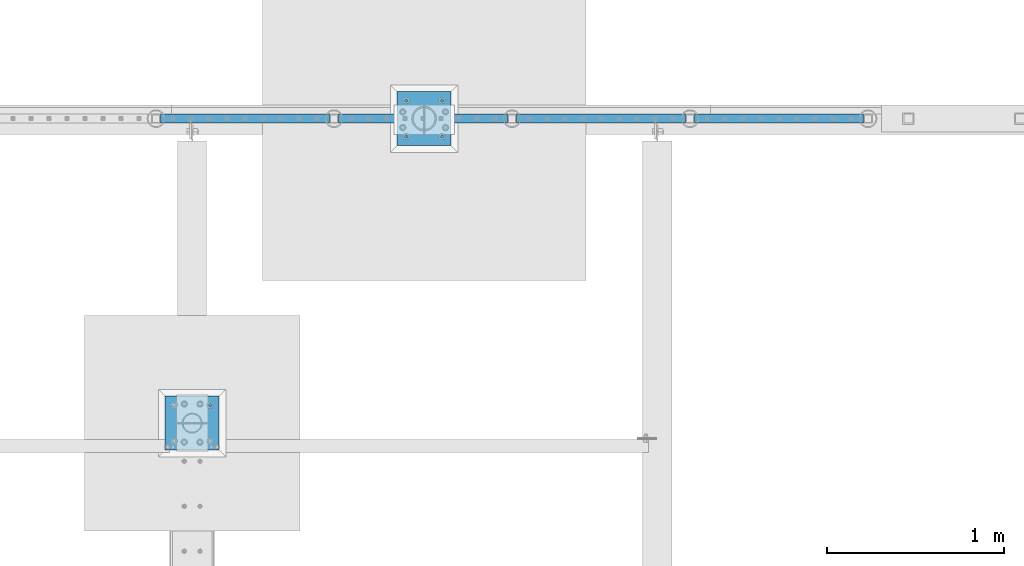
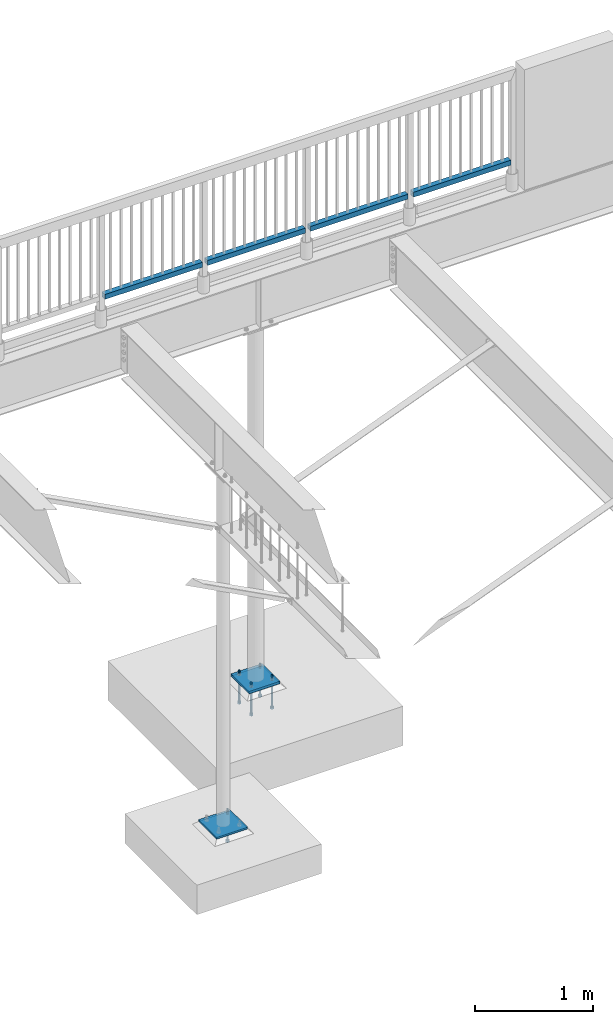
# One storey, part 440 of 975: 13 beams.
"""IFC2X3 building model written with IfcOpenShell, lengths in millimetres."""

from ifc_helpers import new_model, si_unit, frame, origin_with_axes, place, context, subcontext, project, spatial, faceted_brep, material, type_object, element, save


model = new_model("IFC2X3")

# Units and contexts
model_context = context("Model", 3, precision=1e-05, world=origin_with_axes())
body_context = subcontext(model_context, "Body", "Model", "MODEL_VIEW")
ifc_project = project(units=[si_unit("LENGTHUNIT", "METRE", prefix="MILLI"), si_unit("AREAUNIT", "SQUARE_METRE"), si_unit("VOLUMEUNIT", "CUBIC_METRE"), si_unit("MASSUNIT", "GRAM", prefix="KILO"), si_unit("TIMEUNIT", "SECOND"), si_unit("PLANEANGLEUNIT", "RADIAN"), si_unit("SOLIDANGLEUNIT", "STERADIAN"), si_unit("THERMODYNAMICTEMPERATUREUNIT", "DEGREE_CELSIUS"), si_unit("LUMINOUSINTENSITYUNIT", "LUMEN")], contexts=[model_context])

# Site, building, storey
site_placement = place(None, origin_with_axes())
site = spatial("IfcSite", under=ifc_project, at=site_placement, CompositionType="ELEMENT")
building_placement = place(site_placement, origin_with_axes())
building = spatial("IfcBuilding", under=site, at=building_placement, Name="Undefined", CompositionType="ELEMENT")
storey_placement = place(building_placement, origin_with_axes())
storey = spatial("IfcBuildingStorey", under=building, at=storey_placement, Name="Undefined", CompositionType="ELEMENT", Elevation=0.0)

# Beams
ifc_material_1 = material()
beam_type_1 = type_object("IfcBeamType", Name="HSS2X2X.188_TUBES", PredefinedType="NOTDEFINED")
beam_1_placement = place(storey_placement, frame((11043.2860620568, 29962.0937719776, 4229.09986447577), z_axis=(6.77029999806108e-05, 0.999999997708152, 0.0), x_axis=(0.999999997675258, -6.77029999785656e-05, -8.11099999746437e-06)))
element("IfcBeam", 1, at=beam_1_placement, inside=storey, type_object=beam_type_1, material=ifc_material_1, Name="HANDRAIL", ObjectType="HSS2X2X.188_TUBES", context=body_context, shape_type="Brep", body=[
    faceted_brep([(25.4017276789964, 20.6375000000071, -20.6374999999971), (25.401427527162, -20.6374999999998, -20.6375000000007), (980.443132417618, -20.6374999998343, -20.637500000259), (980.443467199178, 20.6375000001717, -20.6375000002517), (25.3986803055723, -20.6374999999962, 20.6375000000189), (980.440337976288, -20.6374999998343, 20.6374999997388), (25.3989757828676, 20.6374999999971, 20.6375000000226), (980.440672757848, 20.6375000001717, 20.6374999997461), (25.4020414068762, 25.4000000000015, -25.4000000000015), (25.3986572424046, 25.3999999999978, 25.3999999999942), (980.440388950952, 25.4000000001733, 25.3999999997504), (980.443828263362, 25.4000000001733, -25.4000000002452), (25.3982760173876, -25.3999999999987, 25.3999999999905), (980.439976912108, -25.399999999835, 25.3999999997395), (25.4017153297937, -25.3999999999996, -25.4000000000051), (980.443416224516, -25.3999999998341, -25.4000000002561)], [[[0, 1, 2, 3]], [[1, 4, 5, 2]], [[4, 6, 7, 5]], [[6, 0, 3, 7]], [[8, 9, 10, 11]], [[9, 12, 13, 10]], [[12, 14, 15, 13]], [[14, 8, 11, 15]], [[13, 15, 11, 10], [5, 7, 3, 2]], [[14, 12, 9, 8], [6, 4, 1, 0]]]),
])
for number, where, z_axis, x_axis, name in (
    (2, (10037.4465056713, 29962.1891583109, 4229.09986484927), (9.48329999537235e-05, 0.999999995503351, 0.0), (0.999999995503351, -9.48329999528176e-05, 0.0), "HANDRAIL"),
    (3, (9031.60674328218, 29962.284544656, 4229.09986522255), (9.48329999537235e-05, 0.999999995503351, 0.0), (0.999999995503351, -9.48329999528176e-05, 0.0), "HANDRAIL"),
    (4, (8025.76698089322, 29962.3799309991, 4229.09986559476), (9.48329999537235e-05, 0.999999995503351, 0.0), (0.999999995503351, -9.48329999528176e-05, 0.0), "HANDRAIL"),
):
    element("IfcBeam", number, at=place(storey_placement, frame(where, z_axis=z_axis, x_axis=x_axis)), inside=storey, type_object=beam_type_1, material=ifc_material_1, Name=name, ObjectType="HSS2X2X.188_TUBES", context=body_context, shape_type="Brep", body=[
        faceted_brep([(25.4019160589687, 20.6374999999998, -20.6375000000517), (25.4019506886925, -20.6374999999998, -20.637500000048), (980.441715548952, -20.6374999999998, -20.6375000016633), (980.441680919226, 20.6374999999998, -20.6375000016596), (25.3980364565286, -20.6374999999998, 20.6374999999571), (980.437801316786, -20.6374999999998, 20.6374999983418), (25.398001826803, 20.6374999999998, 20.6374999999534), (980.437766687061, 20.6374999999998, 20.6374999983454), (25.4023637054033, 25.3999999999996, -25.4000000000487), (25.3975461888931, 25.3999999999996, 25.3999999999578), (980.437311049149, 25.3999999999996, 25.3999999983498), (980.442128565661, 25.3999999999996, -25.4000000016567), (25.3975888100922, -25.3999999999996, 25.3999999999578), (980.43735367035, -25.3999999999996, 25.3999999983498), (25.4024063266043, -25.3999999999996, -25.4000000000487), (980.442171186862, -25.3999999999996, -25.4000000016567)], [[[0, 1, 2, 3]], [[1, 4, 5, 2]], [[4, 6, 7, 5]], [[6, 0, 3, 7]], [[8, 9, 10, 11]], [[9, 12, 13, 10]], [[12, 14, 15, 13]], [[14, 8, 11, 15]], [[13, 15, 11, 10], [5, 7, 3, 2]], [[14, 12, 9, 8], [6, 4, 1, 0]]]),
    ])
ifc_material_2 = material(Name="STEEL/A36")
beam_type_2 = type_object("IfcBeamType", PredefinedType="NOTDEFINED")
beam_2_placement = place(storey_placement, frame((8229.6, 28089.225, -257.175000000002), z_axis=(-0.999999999999998, 6.90000001668524e-08, 0.0), x_axis=(0.0, 1.0, 0.0)))
element("IfcBeam", 5, at=beam_2_placement, inside=storey, type_object=beam_type_2, material=ifc_material_2, Name="PLATE", context=body_context, shape_type="Brep", body=[
    faceted_brep([(0.0, 9.52499999999964, -152.4), (0.0, 9.52499999999964, 152.4), (304.799999999152, 9.52499999999964, 152.4), (304.799999999152, 9.52499999999964, -152.4), (0.0, -9.52499999999964, 152.4), (304.799999999152, -9.52499999999964, 152.4), (0.0, -9.52499999999964, -152.4), (304.799999999152, -9.52499999999964, -152.4)], [[[0, 1, 2, 3]], [[1, 4, 5, 2]], [[4, 6, 7, 5]], [[6, 0, 3, 7]], [[5, 7, 3, 2]], [[6, 4, 1, 0]]]),
])
ifc_material_3 = material(Name="STEEL/F1554-36")
beam_type_3 = type_object("IfcBeamType", PredefinedType="NOTDEFINED")
beam_3_placement = place(storey_placement, frame((8331.19999847412, 28343.225, -304.799999999998), z_axis=(0.0, 1.0, 0.0), x_axis=(0.0, 0.0, -1.0)))
element("IfcBeam", 6, at=beam_3_placement, inside=storey, type_object=beam_type_3, material=ifc_material_3, Name="HEADED_ANCHOR_BOLT", context=body_context, shape_type="Brep", body=[
    faceted_brep([(209.543749999999, -9.13000011446275, 15.8100004196049), (209.543749999999, -18.2600002288382, 4.72937244921923e-11), (228.593749999998, -18.2600002288382, 4.72937244921923e-11), (228.593749999998, -9.13000011446275, 15.8100004196049), (209.543749999999, 9.13000011438271, 15.8100004195576), (228.593749999998, 9.13000011438271, 15.8100004195576), (209.543749999999, 18.2600002288382, -4.72937244921923e-11), (228.593749999998, 18.2600002288382, -4.72937244921923e-11), (209.543749999999, 9.13000011446275, -15.8100004196049), (228.593749999998, 9.13000011446275, -15.8100004196049), (209.543749999999, -9.13000011438271, -15.8100004195576), (228.593749999998, -9.13000011438271, -15.8100004195576), (209.543749999999, -4.4776800552936, 9.29799844178979), (209.543749999999, -8.068500660469, 6.43441456491473), (209.543749999999, -10.0612557561763, 2.2964159705416), (209.543749999999, -10.0612557561617, -2.29641597048976), (209.543749999999, -8.0685006604399, -6.4344145648729), (209.543749999999, -4.47768005524995, -9.29799844176705), (209.543749999999, 2.91038304567337e-11, -10.3199996948015), (209.543749999999, 4.4776800552936, -9.29799844178979), (209.543749999999, 8.068500660469, -6.43441456491473), (209.543749999999, 10.0612557561763, -2.2964159705416), (209.543749999999, 10.0612557561617, 2.29641597048976), (209.543749999999, 8.0685006604399, 6.4344145648729), (209.543749999999, 4.47768005524995, 9.29799844176705), (209.543749999999, -2.91038304567337e-11, 10.3199996948015), (228.593749999998, -2.91038304567337e-11, 10.3199996948015), (228.593749999998, -4.4776800552936, 9.29799844178979), (228.593749999998, -8.068500660469, 6.43441456491473), (228.593749999998, -10.0612557561763, 2.2964159705416), (228.593749999998, -10.0612557561617, -2.29641597048976), (228.593749999998, -8.0685006604399, -6.4344145648729), (228.593749999998, -4.47768005524995, -9.29799844176705), (228.593749999998, 2.91038304567337e-11, -10.3199996948015), (228.593749999998, 4.4776800552936, -9.29799844178979), (228.593749999998, 8.068500660469, -6.43441456491473), (228.593749999998, 10.0612557561763, -2.2964159705416), (228.593749999998, 10.0612557561617, 2.29641597048976), (228.593749999998, 8.0685006604399, 6.4344145648729), (228.593749999998, 4.47768005524995, 9.29799844176705), (0.0, -6.73519209080223, 6.73519209080186), (0.0, -9.52499999999964, 0.0), (228.6, -9.52500000000146, 0.0), (228.6, -6.73519209080405, 6.73519209080223), (-9.87109982941227e-13, -1.20792265079217e-13, 9.52499961853027), (228.6, 0.0, 9.52499999999964), (0.0, 6.73519209080223, 6.73519209080186), (228.6, 6.73519209080405, 6.73519209080223), (0.0, 9.52499999999964, 0.0), (228.6, 9.52500000000146, 0.0), (0.0, 6.73519209080223, -6.73519209080186), (228.6, 6.73519209080405, -6.73519209080223), (2.95075507493764e-12, -1.20792265079217e-13, -9.52499961853027), (228.6, 0.0, -9.52499999999964), (-114.297914995421, -6.36396103067818, 6.36396103068091), (-114.297914995421, -2.18278728425503e-11, 8.99999999997999), (-114.297914995421, 6.36396103064908, 6.36396103064817), (-114.297914995421, 8.99999999997817, -2.27373675443232e-11), (-114.297914995421, 6.36396103067818, -6.36396103068091), (-114.297914995421, 2.18278728425503e-11, -8.99999999997999), (-114.297914995421, -6.36396103064908, -6.36396103064817), (-114.297914995421, -8.99999999997817, 2.27373675443232e-11), (0.0149743263646087, 6.36396103067818, -6.36396103067909), (0.0149743263646087, 0.0, -9.0), (0.0149743263646087, -6.36396103067818, -6.36396103067909), (0.0149743263987148, -8.9999995411581, -1.00796984270346e-06), (0.0149743263646087, -6.36396103067818, 6.36396103067909), (0.0149743263646087, 0.0, 9.0), (0.0149743263646087, 6.36396103067818, 6.36396103067909), (0.0149743263987148, 9.0000004588419, -1.00796984270346e-06), (0.0, -6.73519209080223, -6.73519209080186), (228.6, -6.73519209080405, -6.73519209080223)], [[[0, 1, 2, 3]], [[4, 0, 3, 5]], [[6, 4, 5, 7]], [[8, 6, 7, 9]], [[10, 8, 9, 11]], [[0, 4, 6, 8, 10, 1], [12, 13, 14, 15, 16, 17, 18, 19, 20, 21, 22, 23, 24, 25]], [[12, 25, 26, 27]], [[13, 12, 27, 28]], [[14, 13, 28, 29]], [[15, 14, 29, 30]], [[16, 15, 30, 31]], [[17, 16, 31, 32]], [[18, 17, 32, 33]], [[19, 18, 33, 34]], [[20, 19, 34, 35]], [[21, 20, 35, 36]], [[22, 21, 36, 37]], [[23, 22, 37, 38]], [[24, 23, 38, 39]], [[25, 24, 39, 26]], [[9, 7, 5, 3, 2, 11], [38, 37, 36, 35, 34, 33, 32, 31, 30, 29, 28, 27, 26, 39]], [[1, 10, 11, 2]], [[40, 41, 42, 43]], [[44, 40, 43, 45]], [[46, 44, 45, 47]], [[48, 46, 47, 49]], [[50, 48, 49, 51]], [[52, 50, 51, 53]], [[54, 55, 56, 57, 58, 59, 60, 61]], [[59, 58, 62, 63]], [[60, 59, 63, 64]], [[61, 60, 64, 65]], [[54, 61, 65, 66]], [[55, 54, 66, 67]], [[56, 55, 67, 68]], [[57, 56, 68, 69]], [[58, 57, 69, 62]], [[40, 44, 46, 48, 50, 52, 70, 41], [68, 67, 66, 65, 64, 63, 62, 69]], [[41, 70, 71, 42]], [[53, 51, 49, 47, 45, 43, 42, 71]], [[70, 52, 53, 71]]]),
])
beam_4_placement = place(storey_placement, frame((9642.47499847412, 30064.075, -304.799999999999), z_axis=(0.0, -1.0, 0.0), x_axis=(0.0, 0.0, -1.0)))
element("IfcBeam", 7, at=beam_4_placement, inside=storey, type_object=beam_type_3, material=ifc_material_3, Name="HEADED_ANCHOR_BOLT", context=body_context, shape_type="Brep", body=[
    faceted_brep([(210.34375, -9.13000011444637, 15.8100004196167), (210.34375, -18.2600002288873, 0.0), (229.393749999999, -18.2600002288873, 0.0), (229.393749999999, -9.13000011444637, 15.8100004196167), (210.34375, 9.13000011443546, 15.8100004196167), (229.393749999999, 9.13000011443546, 15.8100004196167), (210.34375, 18.2600002288764, 0.0), (229.393749999999, 18.2600002288764, 0.0), (210.34375, 9.13000011443546, -15.8100004196167), (229.393749999999, 9.13000011443546, -15.8100004196167), (210.34375, -9.13000011444637, -15.8100004196167), (229.393749999999, -9.13000011444637, -15.8100004196167), (210.34375, -4.47768005528815, 9.29799844179888), (210.34375, -8.06850066047991, 6.43441456490837), (210.34375, -10.0612557561972, 2.29641597052159), (210.34375, -10.0612557561972, -2.29641597052159), (210.34375, -8.06850066047991, -6.43441456490837), (210.34375, -4.47768005528815, -9.29799844179888), (210.34375, -5.45696821063757e-12, -10.3199996948242), (210.34375, 4.47768005527723, -9.29799844179888), (210.34375, 8.068500660469, -6.43441456490837), (210.34375, 10.0612557561863, -2.29641597052159), (210.34375, 10.0612557561863, 2.29641597052159), (210.34375, 8.068500660469, 6.43441456490837), (210.34375, 4.47768005527723, 9.29799844179888), (210.34375, -5.45696821063757e-12, 10.3199996948242), (229.393749999999, -5.45696821063757e-12, 10.3199996948242), (229.393749999999, -4.47768005528815, 9.29799844179888), (229.393749999999, -8.06850066047991, 6.43441456490837), (229.393749999999, -10.0612557561972, 2.29641597052159), (229.393749999999, -10.0612557561972, -2.29641597052159), (229.393749999999, -8.06850066047991, -6.43441456490837), (229.393749999999, -4.47768005528815, -9.29799844179888), (229.393749999999, -5.45696821063757e-12, -10.3199996948242), (229.393749999999, 4.47768005527723, -9.29799844179888), (229.393749999999, 8.068500660469, -6.43441456490837), (229.393749999999, 10.0612557561863, -2.29641597052159), (229.393749999999, 10.0612557561863, 2.29641597052159), (229.393749999999, 8.068500660469, 6.43441456490837), (229.393749999999, 4.47768005527723, 9.29799844179888), (0.0, -6.73519209080223, 6.73519209080186), (0.0, -9.52499999999964, 0.0), (228.6, -9.52500000000146, 0.0), (228.6, -6.73519209080405, 6.73519209080223), (-9.87109982941227e-13, -1.20792265079217e-13, 9.52499961853027), (228.6, 0.0, 9.52499999999964), (0.0, 6.73519209080223, 6.73519209080186), (228.6, 6.73519209080405, 6.73519209080223), (0.0, 9.52499999999964, 0.0), (228.6, 9.52500000000146, 0.0), (0.0, 6.73519209080223, -6.73519209080186), (228.6, 6.73519209080405, -6.73519209080223), (2.95075507493764e-12, -1.20792265079217e-13, -9.52499961853027), (228.6, 0.0, -9.52499999999964), (-114.293750057273, -6.36396001342564, 6.36396103067909), (-114.293749999997, 1.01725345302839e-06, 9.0), (-114.293749942721, 6.36396204793255, 6.36396103067909), (-114.293749918997, 9.00000101725345, 0.0), (-114.293749942721, 6.36396204793255, -6.36396103067909), (-114.293749999997, 1.01725345302839e-06, -9.0), (-114.293750057273, -6.36396001342564, -6.36396103067909), (-114.293750080997, -8.99999898274655, 0.0), (0.00625005727778216, 6.36396101919127, -6.36396103067909), (0.00625000000218279, -1.14878275780939e-08, -9.0), (0.00624994272658341, -6.36396104216692, -6.36396103067909), (0.00624991900230043, -9.00000001148783, 0.0), (0.00624994272658341, -6.36396104216692, 6.36396103067909), (0.00625000000218279, -1.14878275780939e-08, 9.0), (0.00625005727778216, 6.36396101919127, 6.36396103067909), (0.00625008100212199, 8.99999998851217, 0.0), (0.0, -6.73519209080223, -6.73519209080186), (228.6, -6.73519209080405, -6.73519209080223)], [[[0, 1, 2, 3]], [[4, 0, 3, 5]], [[6, 4, 5, 7]], [[8, 6, 7, 9]], [[10, 8, 9, 11]], [[0, 4, 6, 8, 10, 1], [12, 13, 14, 15, 16, 17, 18, 19, 20, 21, 22, 23, 24, 25]], [[12, 25, 26, 27]], [[13, 12, 27, 28]], [[14, 13, 28, 29]], [[15, 14, 29, 30]], [[16, 15, 30, 31]], [[17, 16, 31, 32]], [[18, 17, 32, 33]], [[19, 18, 33, 34]], [[20, 19, 34, 35]], [[21, 20, 35, 36]], [[22, 21, 36, 37]], [[23, 22, 37, 38]], [[24, 23, 38, 39]], [[25, 24, 39, 26]], [[9, 7, 5, 3, 2, 11], [38, 37, 36, 35, 34, 33, 32, 31, 30, 29, 28, 27, 26, 39]], [[1, 10, 11, 2]], [[40, 41, 42, 43]], [[44, 40, 43, 45]], [[46, 44, 45, 47]], [[48, 46, 47, 49]], [[50, 48, 49, 51]], [[52, 50, 51, 53]], [[54, 55, 56, 57, 58, 59, 60, 61]], [[59, 58, 62, 63]], [[60, 59, 63, 64]], [[61, 60, 64, 65]], [[54, 61, 65, 66]], [[55, 54, 66, 67]], [[56, 55, 67, 68]], [[57, 56, 68, 69]], [[58, 57, 69, 62]], [[40, 44, 46, 48, 50, 52, 70, 41], [68, 67, 66, 65, 64, 63, 62, 69]], [[41, 70, 71, 42]], [[53, 51, 49, 47, 45, 43, 42, 71]], [[70, 52, 53, 71]]]),
])
beam_5_placement = place(storey_placement, frame((9439.27500152588, 30064.075, -304.799999999999), z_axis=(0.0, -1.0, 0.0), x_axis=(0.0, 0.0, -1.0)))
element("IfcBeam", 8, at=beam_5_placement, inside=storey, type_object=beam_type_3, material=ifc_material_3, Name="HEADED_ANCHOR_BOLT", context=body_context, shape_type="Brep", body=[
    faceted_brep([(210.34375, -9.13000011444637, 15.8100004196167), (210.34375, -18.2600002288873, 0.0), (229.393749999999, -18.2600002288873, 0.0), (229.393749999999, -9.13000011444637, 15.8100004196167), (210.34375, 9.13000011443546, 15.8100004196167), (229.393749999999, 9.13000011443546, 15.8100004196167), (210.34375, 18.2600002288764, 0.0), (229.393749999999, 18.2600002288764, 0.0), (210.34375, 9.13000011443546, -15.8100004196167), (229.393749999999, 9.13000011443546, -15.8100004196167), (210.34375, -9.13000011444637, -15.8100004196167), (229.393749999999, -9.13000011444637, -15.8100004196167), (210.34375, -4.47768005528815, 9.29799844179888), (210.34375, -8.06850066047991, 6.43441456490837), (210.34375, -10.0612557561972, 2.29641597052159), (210.34375, -10.0612557561972, -2.29641597052159), (210.34375, -8.06850066047991, -6.43441456490837), (210.34375, -4.47768005528815, -9.29799844179888), (210.34375, -5.45696821063757e-12, -10.3199996948242), (210.34375, 4.47768005527723, -9.29799844179888), (210.34375, 8.068500660469, -6.43441456490837), (210.34375, 10.0612557561863, -2.29641597052159), (210.34375, 10.0612557561863, 2.29641597052159), (210.34375, 8.068500660469, 6.43441456490837), (210.34375, 4.47768005527723, 9.29799844179888), (210.34375, -5.45696821063757e-12, 10.3199996948242), (229.393749999999, -5.45696821063757e-12, 10.3199996948242), (229.393749999999, -4.47768005528815, 9.29799844179888), (229.393749999999, -8.06850066047991, 6.43441456490837), (229.393749999999, -10.0612557561972, 2.29641597052159), (229.393749999999, -10.0612557561972, -2.29641597052159), (229.393749999999, -8.06850066047991, -6.43441456490837), (229.393749999999, -4.47768005528815, -9.29799844179888), (229.393749999999, -5.45696821063757e-12, -10.3199996948242), (229.393749999999, 4.47768005527723, -9.29799844179888), (229.393749999999, 8.068500660469, -6.43441456490837), (229.393749999999, 10.0612557561863, -2.29641597052159), (229.393749999999, 10.0612557561863, 2.29641597052159), (229.393749999999, 8.068500660469, 6.43441456490837), (229.393749999999, 4.47768005527723, 9.29799844179888), (0.0, -6.73519209080223, 6.73519209080186), (0.0, -9.52499999999964, 0.0), (228.6, -9.52500000000146, 0.0), (228.6, -6.73519209080405, 6.73519209080223), (-9.87109982941227e-13, -1.20792265079217e-13, 9.52499961853027), (228.6, 0.0, 9.52499999999964), (0.0, 6.73519209080223, 6.73519209080186), (228.6, 6.73519209080405, 6.73519209080223), (0.0, 9.52499999999964, 0.0), (228.6, 9.52500000000146, 0.0), (0.0, 6.73519209080223, -6.73519209080186), (228.6, 6.73519209080405, -6.73519209080223), (2.95075507493764e-12, -1.20792265079217e-13, -9.52499961853027), (228.6, 0.0, -9.52499999999964), (-114.293750057273, -6.36396001342564, 6.36396103067909), (-114.293749999997, 1.01725345302839e-06, 9.0), (-114.293749942721, 6.36396204793255, 6.36396103067909), (-114.293749918997, 9.00000101725345, 0.0), (-114.293749942721, 6.36396204793255, -6.36396103067909), (-114.293749999997, 1.01725345302839e-06, -9.0), (-114.293750057273, -6.36396001342564, -6.36396103067909), (-114.293750080997, -8.99999898274655, 0.0), (0.00625005727778216, 6.36396101919127, -6.36396103067909), (0.00625000000218279, -1.14878275780939e-08, -9.0), (0.00624994272658341, -6.36396104216692, -6.36396103067909), (0.00624991900230043, -9.00000001148783, 0.0), (0.00624994272658341, -6.36396104216692, 6.36396103067909), (0.00625000000218279, -1.14878275780939e-08, 9.0), (0.00625005727778216, 6.36396101919127, 6.36396103067909), (0.00625008100212199, 8.99999998851217, 0.0), (0.0, -6.73519209080223, -6.73519209080186), (228.6, -6.73519209080405, -6.73519209080223)], [[[0, 1, 2, 3]], [[4, 0, 3, 5]], [[6, 4, 5, 7]], [[8, 6, 7, 9]], [[10, 8, 9, 11]], [[0, 4, 6, 8, 10, 1], [12, 13, 14, 15, 16, 17, 18, 19, 20, 21, 22, 23, 24, 25]], [[12, 25, 26, 27]], [[13, 12, 27, 28]], [[14, 13, 28, 29]], [[15, 14, 29, 30]], [[16, 15, 30, 31]], [[17, 16, 31, 32]], [[18, 17, 32, 33]], [[19, 18, 33, 34]], [[20, 19, 34, 35]], [[21, 20, 35, 36]], [[22, 21, 36, 37]], [[23, 22, 37, 38]], [[24, 23, 38, 39]], [[25, 24, 39, 26]], [[9, 7, 5, 3, 2, 11], [38, 37, 36, 35, 34, 33, 32, 31, 30, 29, 28, 27, 26, 39]], [[1, 10, 11, 2]], [[40, 41, 42, 43]], [[44, 40, 43, 45]], [[46, 44, 45, 47]], [[48, 46, 47, 49]], [[50, 48, 49, 51]], [[52, 50, 51, 53]], [[54, 55, 56, 57, 58, 59, 60, 61]], [[59, 58, 62, 63]], [[60, 59, 63, 64]], [[61, 60, 64, 65]], [[54, 61, 65, 66]], [[55, 54, 66, 67]], [[56, 55, 67, 68]], [[57, 56, 68, 69]], [[58, 57, 69, 62]], [[40, 44, 46, 48, 50, 52, 70, 41], [68, 67, 66, 65, 64, 63, 62, 69]], [[41, 70, 71, 42]], [[53, 51, 49, 47, 45, 43, 42, 71]], [[70, 52, 53, 71]]]),
])
beam_6_placement = place(storey_placement, frame((9439.27500152588, 29860.8750030518, -304.799999999999), z_axis=(0.0, -1.0, 0.0), x_axis=(0.0, 0.0, -1.0)))
element("IfcBeam", 9, at=beam_6_placement, inside=storey, type_object=beam_type_3, material=ifc_material_3, Name="HEADED_ANCHOR_BOLT", context=body_context, shape_type="Brep", body=[
    faceted_brep([(210.34375, -9.13000011444637, 15.8100004196167), (210.34375, -18.2600002288873, 0.0), (229.393749999999, -18.2600002288873, 0.0), (229.393749999999, -9.13000011444637, 15.8100004196167), (210.34375, 9.13000011443546, 15.8100004196167), (229.393749999999, 9.13000011443546, 15.8100004196167), (210.34375, 18.2600002288764, 0.0), (229.393749999999, 18.2600002288764, 0.0), (210.34375, 9.13000011443546, -15.8100004196167), (229.393749999999, 9.13000011443546, -15.8100004196167), (210.34375, -9.13000011444637, -15.8100004196167), (229.393749999999, -9.13000011444637, -15.8100004196167), (210.34375, -4.47768005528815, 9.29799844179888), (210.34375, -8.06850066047991, 6.43441456490837), (210.34375, -10.0612557561972, 2.29641597052159), (210.34375, -10.0612557561972, -2.29641597052159), (210.34375, -8.06850066047991, -6.43441456490837), (210.34375, -4.47768005528815, -9.29799844179888), (210.34375, -5.45696821063757e-12, -10.3199996948242), (210.34375, 4.47768005527723, -9.29799844179888), (210.34375, 8.068500660469, -6.43441456490837), (210.34375, 10.0612557561863, -2.29641597052159), (210.34375, 10.0612557561863, 2.29641597052159), (210.34375, 8.068500660469, 6.43441456490837), (210.34375, 4.47768005527723, 9.29799844179888), (210.34375, -5.45696821063757e-12, 10.3199996948242), (229.393749999999, -5.45696821063757e-12, 10.3199996948242), (229.393749999999, -4.47768005528815, 9.29799844179888), (229.393749999999, -8.06850066047991, 6.43441456490837), (229.393749999999, -10.0612557561972, 2.29641597052159), (229.393749999999, -10.0612557561972, -2.29641597052159), (229.393749999999, -8.06850066047991, -6.43441456490837), (229.393749999999, -4.47768005528815, -9.29799844179888), (229.393749999999, -5.45696821063757e-12, -10.3199996948242), (229.393749999999, 4.47768005527723, -9.29799844179888), (229.393749999999, 8.068500660469, -6.43441456490837), (229.393749999999, 10.0612557561863, -2.29641597052159), (229.393749999999, 10.0612557561863, 2.29641597052159), (229.393749999999, 8.068500660469, 6.43441456490837), (229.393749999999, 4.47768005527723, 9.29799844179888), (0.0, -6.73519209080223, 6.73519209080186), (0.0, -9.52499999999964, 0.0), (228.6, -9.52500000000146, 0.0), (228.6, -6.73519209080405, 6.73519209080223), (-9.87109982941227e-13, -1.20792265079217e-13, 9.52499961853027), (228.6, 0.0, 9.52499999999964), (0.0, 6.73519209080223, 6.73519209080186), (228.6, 6.73519209080405, 6.73519209080223), (0.0, 9.52499999999964, 0.0), (228.6, 9.52500000000146, 0.0), (0.0, 6.73519209080223, -6.73519209080186), (228.6, 6.73519209080405, -6.73519209080223), (2.95075507493764e-12, -1.20792265079217e-13, -9.52499961853027), (228.6, 0.0, -9.52499999999964), (-114.293750057273, -6.36396001342564, 6.36396103067909), (-114.293749999997, 1.01725345302839e-06, 9.0), (-114.293749942721, 6.36396204793255, 6.36396103067909), (-114.293749918997, 9.00000101725345, 0.0), (-114.293749942721, 6.36396204793255, -6.36396103067909), (-114.293749999997, 1.01725345302839e-06, -9.0), (-114.293750057273, -6.36396001342564, -6.36396103067909), (-114.293750080997, -8.99999898274655, 0.0), (0.00625005727778216, 6.36396101919127, -6.36396103067909), (0.00625000000218279, -1.14878275780939e-08, -9.0), (0.00624994272658341, -6.36396104216692, -6.36396103067909), (0.00624991900230043, -9.00000001148783, 0.0), (0.00624994272658341, -6.36396104216692, 6.36396103067909), (0.00625000000218279, -1.14878275780939e-08, 9.0), (0.00625005727778216, 6.36396101919127, 6.36396103067909), (0.00625008100212199, 8.99999998851217, 0.0), (0.0, -6.73519209080223, -6.73519209080186), (228.6, -6.73519209080405, -6.73519209080223)], [[[0, 1, 2, 3]], [[4, 0, 3, 5]], [[6, 4, 5, 7]], [[8, 6, 7, 9]], [[10, 8, 9, 11]], [[0, 4, 6, 8, 10, 1], [12, 13, 14, 15, 16, 17, 18, 19, 20, 21, 22, 23, 24, 25]], [[12, 25, 26, 27]], [[13, 12, 27, 28]], [[14, 13, 28, 29]], [[15, 14, 29, 30]], [[16, 15, 30, 31]], [[17, 16, 31, 32]], [[18, 17, 32, 33]], [[19, 18, 33, 34]], [[20, 19, 34, 35]], [[21, 20, 35, 36]], [[22, 21, 36, 37]], [[23, 22, 37, 38]], [[24, 23, 38, 39]], [[25, 24, 39, 26]], [[9, 7, 5, 3, 2, 11], [38, 37, 36, 35, 34, 33, 32, 31, 30, 29, 28, 27, 26, 39]], [[1, 10, 11, 2]], [[40, 41, 42, 43]], [[44, 40, 43, 45]], [[46, 44, 45, 47]], [[48, 46, 47, 49]], [[50, 48, 49, 51]], [[52, 50, 51, 53]], [[54, 55, 56, 57, 58, 59, 60, 61]], [[59, 58, 62, 63]], [[60, 59, 63, 64]], [[61, 60, 64, 65]], [[54, 61, 65, 66]], [[55, 54, 66, 67]], [[56, 55, 67, 68]], [[57, 56, 68, 69]], [[58, 57, 69, 62]], [[40, 44, 46, 48, 50, 52, 70, 41], [68, 67, 66, 65, 64, 63, 62, 69]], [[41, 70, 71, 42]], [[53, 51, 49, 47, 45, 43, 42, 71]], [[70, 52, 53, 71]]]),
])
beam_7_placement = place(storey_placement, frame((9642.47499847412, 29860.8750030518, -304.799999999999), z_axis=(0.0, -1.0, 0.0), x_axis=(0.0, 0.0, -1.0)))
element("IfcBeam", 10, at=beam_7_placement, inside=storey, type_object=beam_type_3, material=ifc_material_3, Name="HEADED_ANCHOR_BOLT", context=body_context, shape_type="Brep", body=[
    faceted_brep([(210.34375, -9.13000011444637, 15.8100004196167), (210.34375, -18.2600002288873, 0.0), (229.393749999999, -18.2600002288873, 0.0), (229.393749999999, -9.13000011444637, 15.8100004196167), (210.34375, 9.13000011443546, 15.8100004196167), (229.393749999999, 9.13000011443546, 15.8100004196167), (210.34375, 18.2600002288764, 0.0), (229.393749999999, 18.2600002288764, 0.0), (210.34375, 9.13000011443546, -15.8100004196167), (229.393749999999, 9.13000011443546, -15.8100004196167), (210.34375, -9.13000011444637, -15.8100004196167), (229.393749999999, -9.13000011444637, -15.8100004196167), (210.34375, -4.47768005528815, 9.29799844179888), (210.34375, -8.06850066047991, 6.43441456490837), (210.34375, -10.0612557561972, 2.29641597052159), (210.34375, -10.0612557561972, -2.29641597052159), (210.34375, -8.06850066047991, -6.43441456490837), (210.34375, -4.47768005528815, -9.29799844179888), (210.34375, -5.45696821063757e-12, -10.3199996948242), (210.34375, 4.47768005527723, -9.29799844179888), (210.34375, 8.068500660469, -6.43441456490837), (210.34375, 10.0612557561863, -2.29641597052159), (210.34375, 10.0612557561863, 2.29641597052159), (210.34375, 8.068500660469, 6.43441456490837), (210.34375, 4.47768005527723, 9.29799844179888), (210.34375, -5.45696821063757e-12, 10.3199996948242), (229.393749999999, -5.45696821063757e-12, 10.3199996948242), (229.393749999999, -4.47768005528815, 9.29799844179888), (229.393749999999, -8.06850066047991, 6.43441456490837), (229.393749999999, -10.0612557561972, 2.29641597052159), (229.393749999999, -10.0612557561972, -2.29641597052159), (229.393749999999, -8.06850066047991, -6.43441456490837), (229.393749999999, -4.47768005528815, -9.29799844179888), (229.393749999999, -5.45696821063757e-12, -10.3199996948242), (229.393749999999, 4.47768005527723, -9.29799844179888), (229.393749999999, 8.068500660469, -6.43441456490837), (229.393749999999, 10.0612557561863, -2.29641597052159), (229.393749999999, 10.0612557561863, 2.29641597052159), (229.393749999999, 8.068500660469, 6.43441456490837), (229.393749999999, 4.47768005527723, 9.29799844179888), (0.0, -6.73519209080223, 6.73519209080186), (0.0, -9.52499999999964, 0.0), (228.6, -9.52500000000146, 0.0), (228.6, -6.73519209080405, 6.73519209080223), (-9.87109982941227e-13, -1.20792265079217e-13, 9.52499961853027), (228.6, 0.0, 9.52499999999964), (0.0, 6.73519209080223, 6.73519209080186), (228.6, 6.73519209080405, 6.73519209080223), (0.0, 9.52499999999964, 0.0), (228.6, 9.52500000000146, 0.0), (0.0, 6.73519209080223, -6.73519209080186), (228.6, 6.73519209080405, -6.73519209080223), (2.95075507493764e-12, -1.20792265079217e-13, -9.52499961853027), (228.6, 0.0, -9.52499999999964), (-114.293750057273, -6.36396001342564, 6.36396103067909), (-114.293749999997, 1.01725345302839e-06, 9.0), (-114.293749942721, 6.36396204793255, 6.36396103067909), (-114.293749918997, 9.00000101725345, 0.0), (-114.293749942721, 6.36396204793255, -6.36396103067909), (-114.293749999997, 1.01725345302839e-06, -9.0), (-114.293750057273, -6.36396001342564, -6.36396103067909), (-114.293750080997, -8.99999898274655, 0.0), (0.00625005727778216, 6.36396101919127, -6.36396103067909), (0.00625000000218279, -1.14878275780939e-08, -9.0), (0.00624994272658341, -6.36396104216692, -6.36396103067909), (0.00624991900230043, -9.00000001148783, 0.0), (0.00624994272658341, -6.36396104216692, 6.36396103067909), (0.00625000000218279, -1.14878275780939e-08, 9.0), (0.00625005727778216, 6.36396101919127, 6.36396103067909), (0.00625008100212199, 8.99999998851217, 0.0), (0.0, -6.73519209080223, -6.73519209080186), (228.6, -6.73519209080405, -6.73519209080223)], [[[0, 1, 2, 3]], [[4, 0, 3, 5]], [[6, 4, 5, 7]], [[8, 6, 7, 9]], [[10, 8, 9, 11]], [[0, 4, 6, 8, 10, 1], [12, 13, 14, 15, 16, 17, 18, 19, 20, 21, 22, 23, 24, 25]], [[12, 25, 26, 27]], [[13, 12, 27, 28]], [[14, 13, 28, 29]], [[15, 14, 29, 30]], [[16, 15, 30, 31]], [[17, 16, 31, 32]], [[18, 17, 32, 33]], [[19, 18, 33, 34]], [[20, 19, 34, 35]], [[21, 20, 35, 36]], [[22, 21, 36, 37]], [[23, 22, 37, 38]], [[24, 23, 38, 39]], [[25, 24, 39, 26]], [[9, 7, 5, 3, 2, 11], [38, 37, 36, 35, 34, 33, 32, 31, 30, 29, 28, 27, 26, 39]], [[1, 10, 11, 2]], [[40, 41, 42, 43]], [[44, 40, 43, 45]], [[46, 44, 45, 47]], [[48, 46, 47, 49]], [[50, 48, 49, 51]], [[52, 50, 51, 53]], [[54, 55, 56, 57, 58, 59, 60, 61]], [[59, 58, 62, 63]], [[60, 59, 63, 64]], [[61, 60, 64, 65]], [[54, 61, 65, 66]], [[55, 54, 66, 67]], [[56, 55, 67, 68]], [[57, 56, 68, 69]], [[58, 57, 69, 62]], [[40, 44, 46, 48, 50, 52, 70, 41], [68, 67, 66, 65, 64, 63, 62, 69]], [[41, 70, 71, 42]], [[53, 51, 49, 47, 45, 43, 42, 71]], [[70, 52, 53, 71]]]),
])
beam_type_4 = type_object("IfcBeamType", PredefinedType="NOTDEFINED")
for number, where, z_axis, x_axis, name in (
    (11, (8229.6, 28089.225, -265.112500000001), (-0.999999999999998, 6.90000001668524e-08, 0.0), (0.0, 1.0, 0.0), "TEMPLATE"),
    (12, (9540.875, 29810.075, -265.112500000001), (-0.999999999999998, 6.90000001668524e-08, 0.0), (0.0, 1.0, 0.0), "TEMPLATE"),
):
    element("IfcBeam", number, at=place(storey_placement, frame(where, z_axis=z_axis, x_axis=x_axis)), inside=storey, type_object=beam_type_4, material=ifc_material_2, Name=name, context=body_context, shape_type="Brep", body=[
        faceted_brep([(0.0, 1.58750000000009, -152.4), (0.0, 1.58750000000009, 152.4), (304.799999999153, 1.58750000000001, 152.400000000001), (304.799999999153, 1.58750000000001, -152.400000000001), (0.0, -1.58750000000009, 152.4), (304.799999999153, -1.58750000000001, 152.400000000001), (0.0, -1.58750000000009, -152.4), (304.799999999153, -1.58750000000001, -152.400000000001)], [[[0, 1, 2, 3]], [[1, 4, 5, 2]], [[4, 6, 7, 5]], [[6, 0, 3, 7]], [[5, 7, 3, 2]], [[6, 4, 1, 0]]]),
    ])
beam_type_5 = type_object("IfcBeamType", PredefinedType="NOTDEFINED")
beam_8_placement = place(storey_placement, frame((9540.875, 29810.075, -254.0), z_axis=(-0.999999999999998, 6.90000001668524e-08, 0.0), x_axis=(0.0, 1.0, 0.0)))
element("IfcBeam", 13, at=beam_8_placement, inside=storey, type_object=beam_type_5, material=ifc_material_2, Name="PLATE", context=body_context, shape_type="Brep", body=[
    faceted_brep([(0.0, 12.7, -152.400000000001), (-1.36424205265939e-12, 12.7, 152.400009155273), (304.800000000003, 12.7, 152.400000000001), (304.800000000003, 12.7, -152.400000000001), (0.0, -12.7, 152.400000000001), (304.800000000003, -12.7, 152.400000000001), (0.0, -12.7, -152.400000000001), (304.800000000003, -12.7, -152.400000000001)], [[[0, 1, 2, 3]], [[1, 4, 5, 2]], [[4, 6, 7, 5]], [[6, 0, 3, 7]], [[5, 7, 3, 2]], [[6, 4, 1, 0]]]),
])

save(model, "model.ifc")
